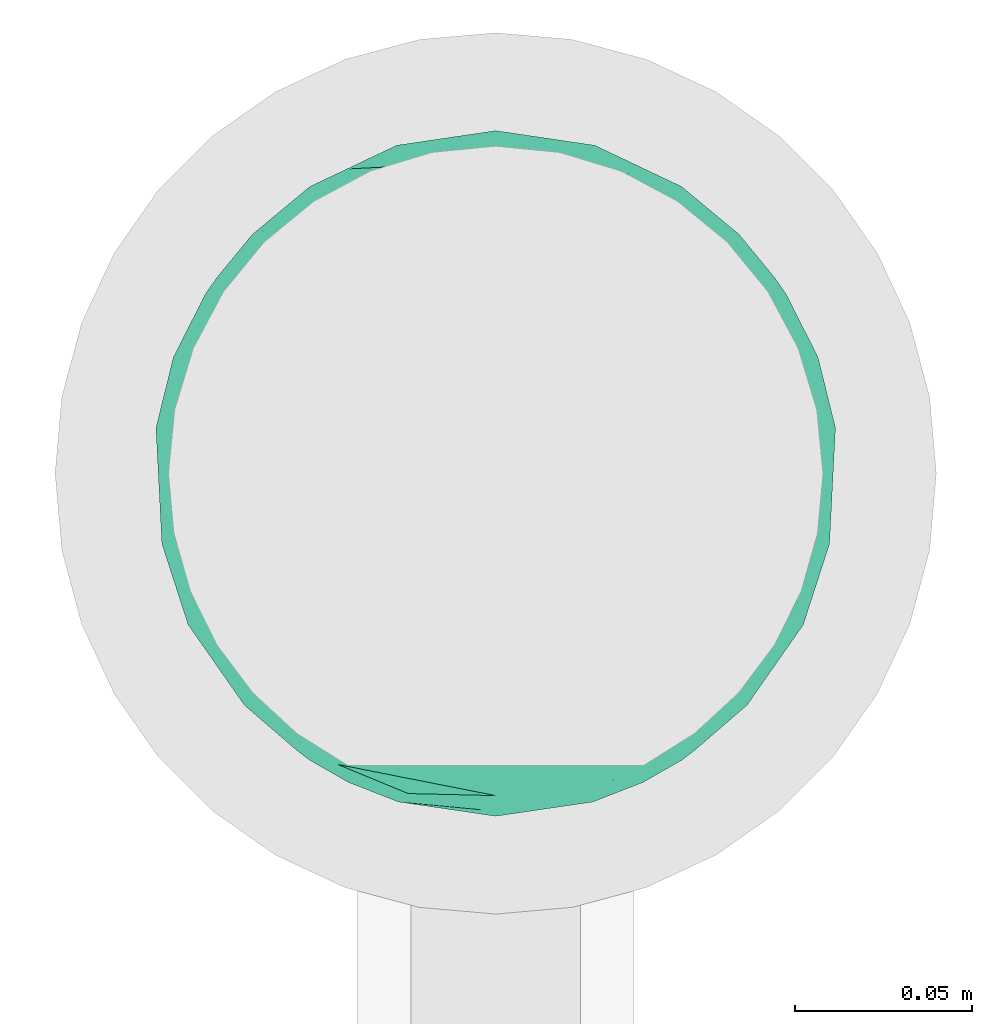
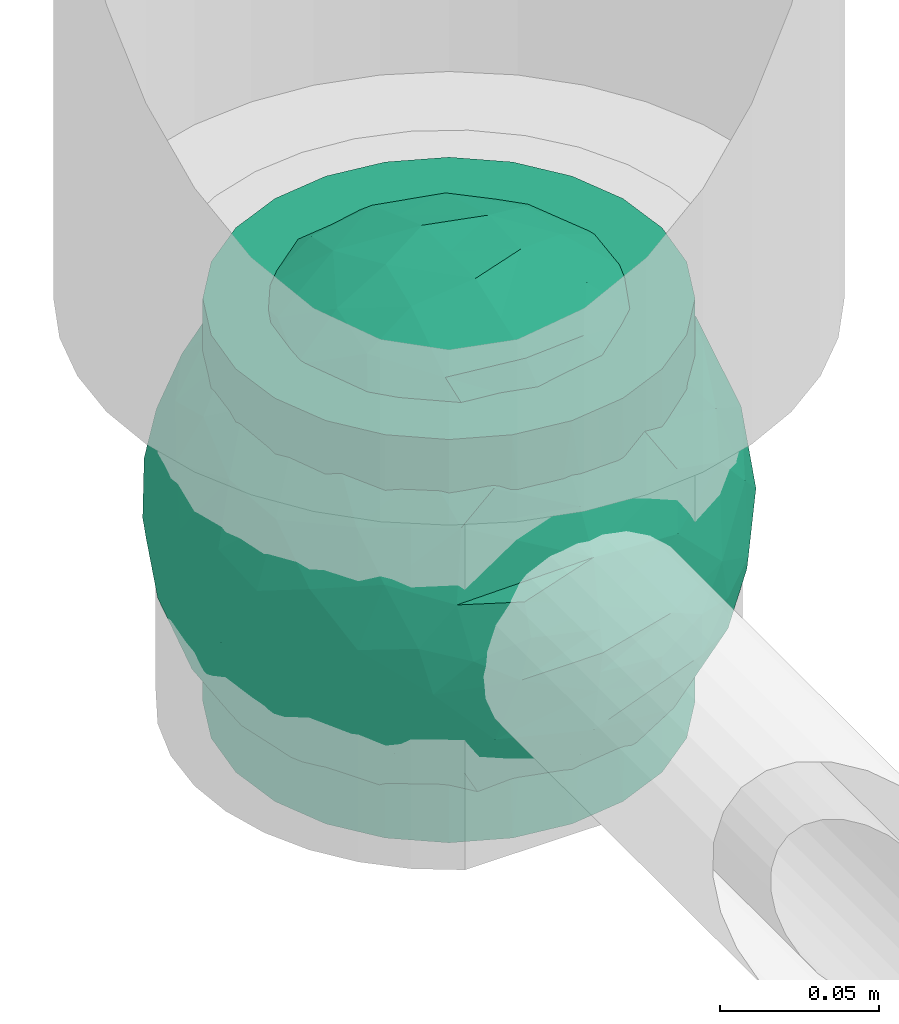
# One storey, part 33 of 39: 1 flow fitting.
"""IFC2X3 building model written with IfcOpenShell, lengths in millimetres."""

from ifc_helpers import new_model, entity, si_unit, converted_unit, derived_unit, direction, frame, origin, place, context, subcontext, project, spatial, faceted_brep, source, transform, mapped, material, material_list, type_object, type_shapes, element, save


model = new_model("IFC2X3")

# Units and contexts
model_context = context("Model", 3, precision=0.01, world=origin(), true_north=direction((6.12303176911189e-17, 1.0)))
body_context = subcontext(model_context, "Body", "Model", "MODEL_VIEW")
ifc_project = project(units=[si_unit("LENGTHUNIT", "METRE", prefix="MILLI"), si_unit("AREAUNIT", "SQUARE_METRE"), si_unit("VOLUMEUNIT", "CUBIC_METRE"), converted_unit("PLANEANGLEUNIT", "DEGREE", entity("IfcRatioMeasure", 0.0174532925199433), si_unit("PLANEANGLEUNIT", "RADIAN"), dimensions=[0, 0, 0, 0, 0, 0, 0]), si_unit("MASSUNIT", "GRAM", prefix="KILO"), derived_unit("MASSDENSITYUNIT", [(si_unit("MASSUNIT", "GRAM", prefix="KILO"), 1), (si_unit("LENGTHUNIT", "METRE"), -3)]), derived_unit("MOMENTOFINERTIAUNIT", [(si_unit("LENGTHUNIT", "METRE"), 4)]), si_unit("TIMEUNIT", "SECOND"), si_unit("FREQUENCYUNIT", "HERTZ"), si_unit("THERMODYNAMICTEMPERATUREUNIT", "DEGREE_CELSIUS"), derived_unit("THERMALTRANSMITTANCEUNIT", [(si_unit("MASSUNIT", "GRAM", prefix="KILO"), 1), (si_unit("THERMODYNAMICTEMPERATUREUNIT", "KELVIN"), -1), (si_unit("TIMEUNIT", "SECOND"), -3)]), derived_unit("VOLUMETRICFLOWRATEUNIT", [(si_unit("LENGTHUNIT", "METRE"), 3), (si_unit("TIMEUNIT", "SECOND"), -1)]), derived_unit("MASSFLOWRATEUNIT", [(si_unit("MASSUNIT", "GRAM", prefix="KILO"), 1), (si_unit("TIMEUNIT", "SECOND"), -1)]), derived_unit("ROTATIONALFREQUENCYUNIT", [(si_unit("TIMEUNIT", "SECOND"), -1)]), si_unit("ELECTRICCURRENTUNIT", "AMPERE"), si_unit("ELECTRICVOLTAGEUNIT", "VOLT"), si_unit("POWERUNIT", "WATT"), si_unit("FORCEUNIT", "NEWTON", prefix="KILO"), si_unit("ILLUMINANCEUNIT", "LUX"), si_unit("LUMINOUSFLUXUNIT", "LUMEN"), si_unit("LUMINOUSINTENSITYUNIT", "CANDELA"), derived_unit("USERDEFINED", [(si_unit("MASSUNIT", "GRAM", prefix="KILO"), -1), (si_unit("LENGTHUNIT", "METRE"), -2), (si_unit("TIMEUNIT", "SECOND"), 3), (si_unit("LUMINOUSFLUXUNIT", "LUMEN"), 1)]), derived_unit("LINEARVELOCITYUNIT", [(si_unit("LENGTHUNIT", "METRE"), 1), (si_unit("TIMEUNIT", "SECOND"), -1)]), si_unit("PRESSUREUNIT", "PASCAL"), derived_unit("USERDEFINED", [(si_unit("LENGTHUNIT", "METRE"), -2), (si_unit("MASSUNIT", "GRAM", prefix="KILO"), 1), (si_unit("TIMEUNIT", "SECOND"), -2)]), derived_unit("LINEARFORCEUNIT", [(si_unit("MASSUNIT", "GRAM", prefix="KILO"), 1), (si_unit("LENGTHUNIT", "METRE"), 1), (si_unit("TIMEUNIT", "SECOND"), -2), (si_unit("LENGTHUNIT", "METRE"), -1)]), derived_unit("PLANARFORCEUNIT", [(si_unit("MASSUNIT", "GRAM", prefix="KILO"), 1), (si_unit("LENGTHUNIT", "METRE"), 1), (si_unit("TIMEUNIT", "SECOND"), -2), (si_unit("LENGTHUNIT", "METRE"), -2)])], contexts=[model_context])

# Site, building, storey
site_placement = place(None, origin())
site = spatial("IfcSite", under=ifc_project, at=site_placement, CompositionType="ELEMENT")
building_placement = place(site_placement, origin())
building = spatial("IfcBuilding", under=site, at=building_placement, CompositionType="ELEMENT")
storey_placement = place(building_placement, frame((0.0, 0.0, 24000.0)))
storey = spatial("IfcBuildingStorey", under=building, at=storey_placement, Name="07", CompositionType="ELEMENT", Elevation=24000.0)

# Flow fitting
ifc_material_1 = material()
ifc_material_2 = material(Name="ADSK_")
ifc_material_list = material_list([ifc_material_1, ifc_material_2])
pipe_fitting_type = type_object("IfcPipeFittingType", Name="ADSK_1", PredefinedType="NOTDEFINED", material=ifc_material_list)
shared_shape = source(origin(), body_context, "Body", "Brep", [
    faceted_brep([(-77.5, 38.75, -67.12), (-77.5, 20.06, -74.86), (-77.5, 0.0, -77.5), (-77.5, -20.06, -74.86), (-77.5, -38.75, -67.12), (-77.5, -54.8, -54.8), (-77.5, -67.12, -38.75), (-77.5, -74.86, -20.06), (-77.5, -76.18, -10.03), (-77.5, -77.5, 0.0), (-77.5, -76.18, 10.03), (-77.5, -74.86, 20.06), (-77.5, -67.12, 38.75), (-77.5, -54.8, 54.8), (-77.5, -38.75, 67.12), (-77.5, -20.06, 74.86), (-77.5, 0.0, 77.5), (-77.5, 20.06, 74.86), (-77.5, 38.75, 67.12), (-77.5, 54.8, 54.8), (-77.5, 67.12, 38.75), (-77.5, 74.86, 20.06), (-77.5, 77.5, 0.0), (-77.5, 74.86, -20.06), (-77.5, 67.12, -38.75), (-77.5, 54.8, -54.8), (77.5, 0.0, -77.5), (77.5, 20.06, -74.86), (77.5, 38.75, -67.12), (77.5, 54.8, -54.8), (77.5, 67.12, -38.75), (77.5, 74.86, -20.06), (77.5, 77.5, 0.0), (77.5, 74.86, 20.06), (77.5, 67.12, 38.75), (77.5, 54.8, 54.8), (77.5, 38.75, 67.12), (77.5, 20.06, 74.86), (77.5, 0.0, 77.5), (77.5, -20.06, 74.86), (77.5, -38.75, 67.12), (77.5, -54.8, 54.8), (77.5, -67.12, 38.75), (77.5, -74.86, 20.06), (77.5, -76.18, 10.03), (77.5, -77.5, 0.0), (77.5, -76.18, -10.03), (77.5, -74.86, -20.06), (77.5, -67.12, -38.75), (77.5, -54.8, -54.8), (77.5, -38.75, -67.12), (77.5, -20.06, -74.86), (21.13, -77.11, 7.72), (21.82, -77.31, 3.86), (22.5, -77.5, 0.0), (17.23, -76.14, 14.47), (3.92, -74.27, 22.16), (7.6, -74.64, 20.81), (11.27, -75.01, 19.47), (-17.23, -76.14, 14.47), (-21.13, -77.11, 7.72), (-22.5, -77.5, 0.0), (-21.82, -77.31, 3.86), (-11.28, -75.01, 19.47), (-7.6, -74.64, 20.81), (-3.93, -74.27, 22.15), (0.0, -74.27, 22.15), (3.92, -74.27, -22.16), (11.27, -75.01, -19.47), (7.6, -74.64, -20.81), (21.82, -77.31, -3.86), (21.13, -77.11, -7.72), (17.23, -76.14, -14.47), (-21.13, -77.11, -7.72), (0.0, -74.27, -22.15), (-3.93, -74.27, -22.15), (-7.6, -74.64, -20.81), (-11.28, -75.01, -19.47), (-17.23, -76.14, -14.47), (-21.82, -77.31, -3.86), (0.0, -82.5, -22.5), (5.82, -82.5, -21.73), (11.25, -82.5, -19.49), (15.91, -82.5, -15.91), (19.49, -82.5, -11.25), (21.73, -82.5, -5.82), (22.5, -82.5, 0.0), (21.73, -82.5, 5.82), (19.49, -82.5, 11.25), (15.91, -82.5, 15.91), (11.25, -82.5, 19.49), (5.82, -82.5, 21.73), (0.0, -82.5, 22.5), (-5.82, -82.5, 21.73), (-11.25, -82.5, 19.49), (-15.91, -82.5, 15.91), (-19.49, -82.5, 11.25), (-21.73, -82.5, 5.82), (-22.5, -82.5, 0.0), (-21.73, -82.5, -5.82), (-19.49, -82.5, -11.25), (-15.91, -82.5, -15.91), (-11.25, -82.5, -19.49), (-5.82, -82.5, -21.73)], [[[0, 1, 2, 3, 4, 5, 6, 7, 8, 9, 10, 11, 12, 13, 14, 15, 16, 17, 18, 19, 20, 21, 22, 23, 24, 25]], [[26, 27, 28, 29, 30, 31, 32, 33, 34, 35, 36, 37, 38, 39, 40, 41, 42, 43, 44, 45, 46, 47, 48, 49, 50, 51]], [[45, 52, 53, 54]], [[55, 52, 44]], [[44, 43, 55]], [[56, 42, 12]], [[43, 56, 57, 58]], [[43, 58, 55]], [[56, 43, 42]], [[42, 41, 13, 12]], [[59, 10, 60]], [[9, 60, 10]], [[9, 61, 62, 60]], [[59, 11, 10]], [[11, 63, 64, 65]], [[65, 12, 11]], [[12, 65, 66, 56]], [[63, 11, 59]], [[52, 45, 44]], [[41, 40, 14, 13]], [[16, 15, 39, 38]], [[15, 14, 40, 39]], [[17, 16, 38, 37]], [[34, 33, 21, 20]], [[19, 18, 36, 35]], [[20, 19, 35, 34]], [[37, 36, 18, 17]], [[22, 21, 33, 32]], [[24, 23, 31, 30]], [[23, 22, 32, 31]], [[25, 24, 30, 29]], [[26, 51, 3, 2]], [[1, 0, 28, 27]], [[2, 1, 27, 26]], [[29, 28, 0, 25]], [[4, 3, 51, 50]], [[50, 49, 5, 4]], [[48, 47, 67]], [[6, 48, 67]], [[48, 6, 5, 49]], [[47, 68, 69, 67]], [[45, 54, 70, 71]], [[68, 47, 72]], [[47, 46, 72]], [[73, 9, 8]], [[46, 45, 71]], [[6, 67, 74, 75]], [[7, 6, 75]], [[7, 75, 76, 77]], [[8, 78, 73]], [[72, 46, 71]], [[9, 73, 79, 61]], [[7, 78, 8]], [[78, 7, 77]], [[80, 81, 82, 83, 84, 85, 86, 87, 88, 89, 90, 91, 92, 93, 94, 95, 96, 97, 98, 99, 100, 101, 102, 103]], [[97, 62, 98]], [[59, 96, 95]], [[97, 96, 60]], [[95, 94, 63]], [[97, 60, 62]], [[62, 61, 98]], [[60, 96, 59]], [[64, 63, 94]], [[93, 65, 64]], [[63, 59, 95]], [[92, 56, 66, 65]], [[90, 57, 91]], [[53, 52, 87]], [[56, 92, 91]], [[57, 90, 58]], [[55, 89, 88]], [[90, 89, 58]], [[52, 88, 87]], [[89, 55, 58]], [[56, 91, 57]], [[53, 86, 54]], [[86, 53, 87]], [[52, 55, 88]], [[64, 94, 93]], [[92, 65, 93]], [[85, 70, 86]], [[72, 84, 83]], [[85, 84, 71]], [[83, 82, 68]], [[85, 71, 70]], [[70, 54, 86]], [[71, 84, 72]], [[69, 68, 82]], [[81, 67, 69]], [[68, 72, 83]], [[80, 75, 74, 67]], [[102, 76, 103]], [[79, 73, 99]], [[75, 80, 103]], [[76, 102, 77]], [[100, 78, 101]], [[101, 77, 102]], [[99, 73, 100]], [[101, 78, 77]], [[75, 103, 76]], [[79, 98, 61]], [[98, 79, 99]], [[73, 78, 100]], [[69, 82, 81]], [[80, 67, 81]]]),
    faceted_brep([(74.09, -36.62, -50.54), (86.5, -25.35, -35.5), (82.61, -45.18, -22.81), (-16.75, -33.7, -89.27), (0.0, -42.78, -86.92), (-23.87, -49.97, -79.49), (73.94, -14.61, -60.86), (53.84, -28.63, -75.28), (-16.57, 93.95, 0.0), (-18.09, 86.11, -40.53), (-32.84, 86.73, -28.0), (-44.04, -10.15, -85.69), (-19.2, 4.88, -94.83), (-22.92, -15.62, -92.82), (89.65, 32.63, 0.0), (82.61, 44.34, -24.37), (83.9, 48.44, 0.0), (47.7, -82.62, 0.0), (60.26, -69.94, -29.38), (62.27, -74.21, 0.0), (95.4, 0.0, 0.0), (95.4, -16.82, 0.0), (94.13, -8.44, -21.26), (93.14, 13.95, -22.71), (95.4, 16.82, 0.0), (76.54, 8.21, -58.81), (74.09, 36.62, -50.54), (84.96, 22.7, -40.64), (28.25, -36.42, -85.21), (19.67, -61.78, -71.98), (-67.45, 51.53, -46.69), (-45.73, 54.97, -65.36), (-59.68, 42.12, -63.64), (47.7, 82.62, 0.0), (62.27, 74.21, 0.0), (59.48, 63.11, -43.18), (-48.12, -74.69, -38.62), (-33.13, -91.03, 0.0), (-47.7, -82.62, 0.0), (72.35, 57.3, -29.46), (60.01, 43.15, -62.62), (62.52, -52.48, -52.18), (45.73, -54.97, -65.36), (-62.27, -74.21, 0.0), (-73.08, -61.32, 0.0), (-72.41, -59.62, -24.21), (7.26, -81.07, -52.53), (35.35, -68.17, -59.06), (27.87, -86.63, -33.22), (-74.09, -36.62, -50.54), (-84.35, -21.79, -42.37), (-76.59, -6.33, -58.98), (61.55, 0.0, -74.81), (-61.55, 0.0, -74.81), (-79.37, 15.54, -53.33), (-95.4, -16.82, 0.0), (-92.58, -16.52, -23.25), (-89.65, -32.63, 0.0), (63.81, 22.67, -69.28), (-18.69, 68.07, -66.35), (-42.94, 76.94, -40.26), (-74.09, 36.62, -50.54), (-43.64, 36.19, -78.55), (-65.1, 21.71, -68.38), (44.46, 15.06, -84.74), (-65.04, -21.76, -68.42), (-94.63, 4.93, -20.13), (-87.93, 0.0, -40.67), (-89.65, 32.63, 0.0), (-89.27, 26.35, -26.85), (27.96, 84.78, -37.61), (7.26, 81.07, -52.53), (1.19, 92.73, -28.0), (3.41, -92.84, -27.46), (-8.28, -95.41, 0.0), (-11.9, -93.14, -23.83), (73.08, 61.32, 0.0), (87.93, 0.0, -40.67), (73.08, -61.32, 0.0), (83.9, -48.44, 0.0), (-73.08, 61.32, 0.0), (-82.24, 45.34, -23.77), (-83.9, 48.44, 0.0), (-63.57, -59.47, -42.5), (-45.73, -54.97, -65.36), (-82.58, -43.28, -26.32), (29.11, 48.1, -78.89), (45.73, 54.97, -65.36), (44.58, 36.0, -78.11), (-61.2, 65.56, -36.61), (-6.93, -65.5, -71.03), (30.56, -5.14, -91.79), (9.54, -19.86, -94.34), (0.0, 12.89, -96.01), (47.81, -10.83, -83.56), (89.65, -32.63, 0.0), (44.95, 76.64, -38.61), (33.13, 91.03, 0.0), (28.53, 69.09, -61.62), (-51.45, 14.65, -80.76), (22.17, 26.71, -90.44), (33.13, -91.03, 0.0), (44.95, -76.64, -38.61), (72.35, -57.3, -29.46), (16.57, -93.95, 0.0), (-15.25, 22.47, -92.99), (2.72, 32.92, -91.07), (8.92, 50.75, -82.03), (9.42, 67.57, -68.78), (16.57, 93.95, 0.0), (-5.45, -87.35, -41.54), (8.28, -95.41, 0.0), (0.0, -96.88, 0.0), (-24.34, -90.45, -24.71), (-25.14, -82.23, -44.62), (-16.57, -93.95, 0.0), (-9.92, -78.26, -56.23), (-30.26, -67.58, -62.46), (-40.87, -32.58, -81.57), (-34.66, 17.97, -88.66), (-59.69, -42.16, -63.59), (-16.8, 39.61, -86.8), (-28.19, 53.95, -75.36), (-10.32, 55.25, -78.9), (-57.91, -73.21, -25.92), (-83.9, -48.44, 0.0), (-95.4, 0.0, 0.0), (-95.4, 16.82, 0.0), (-72.43, 58.81, -26.08), (-62.27, 74.21, 0.0), (-47.7, 82.62, 0.0), (-33.13, 91.03, 0.0), (0.0, 96.87, 0.0), (-74.09, -36.62, 50.54), (-86.5, -25.35, 35.5), (-82.61, -45.18, 22.81), (16.75, -33.7, 89.27), (0.0, -42.78, 86.92), (23.87, -49.97, 79.49), (-73.94, -14.61, 60.86), (-53.84, -28.63, 75.28), (18.09, 86.11, 40.53), (32.84, 86.73, 28.0), (44.04, -10.15, 85.69), (19.2, 4.88, 94.83), (22.92, -15.62, 92.82), (-82.61, 44.34, 24.37), (-60.26, -69.94, 29.38), (-94.13, -8.44, 21.26), (-93.14, 13.95, 22.71), (-76.54, 8.21, 58.81), (-74.09, 36.62, 50.54), (-84.96, 22.7, 40.64), (-28.25, -36.42, 85.21), (-19.67, -61.78, 71.98), (67.45, 51.53, 46.69), (45.73, 54.97, 65.36), (59.68, 42.12, 63.64), (-28.53, 69.09, 61.62), (-45.73, 54.97, 65.36), (-29.11, 48.1, 78.89), (48.12, -74.69, 38.62), (-59.48, 63.11, 43.18), (-72.35, 57.3, 29.46), (-60.01, 43.15, 62.62), (-35.35, -68.17, 59.06), (-7.26, -81.07, 52.53), (72.41, -59.62, 24.21), (-3.41, -92.84, 27.46), (74.09, -36.62, 50.54), (84.35, -21.79, 42.37), (76.59, -6.33, 58.98), (-61.55, 0.0, 74.81), (61.55, 0.0, 74.81), (79.37, 15.54, 53.33), (92.58, -16.52, 23.25), (-63.81, 22.67, 69.28), (18.69, 68.07, 66.35), (42.94, 76.94, 40.26), (74.09, 36.62, 50.54), (43.64, 36.19, 78.55), (65.1, 21.71, 68.38), (-44.46, 15.06, 84.74), (65.04, -21.76, 68.42), (94.63, 4.93, 20.13), (87.93, 0.0, 40.67), (89.27, 26.35, 26.85), (-27.96, 84.78, 37.61), (-7.26, 81.07, 52.53), (-1.19, 92.73, 28.0), (11.9, -93.14, 23.83), (-87.93, 0.0, 40.67), (82.24, 45.34, 23.77), (63.57, -59.47, 42.5), (45.73, -54.97, 65.36), (82.58, -43.28, 26.32), (-44.58, 36.0, 78.11), (61.2, 65.56, 36.61), (25.14, -82.23, 44.62), (5.45, -87.35, 41.54), (24.34, -90.45, 24.71), (6.93, -65.5, 71.03), (-30.56, -5.14, 91.79), (-9.54, -19.86, 94.34), (0.0, 12.89, 96.01), (-47.81, -10.83, 83.56), (-44.95, 76.64, 38.61), (51.45, 14.65, 80.76), (-62.52, -52.48, 52.18), (-45.73, -54.97, 65.36), (-22.17, 26.71, 90.44), (-44.95, -76.64, 38.61), (-72.35, -57.3, 29.46), (-27.87, -86.63, 33.22), (15.25, 22.47, 92.99), (-2.72, 32.92, 91.07), (-8.92, 50.75, 82.03), (-9.42, 67.57, 68.78), (9.92, -78.26, 56.23), (30.26, -67.58, 62.46), (40.87, -32.58, 81.57), (34.66, 17.97, 88.66), (59.69, -42.16, 63.59), (16.8, 39.61, 86.8), (28.19, 53.95, 75.36), (10.32, 55.25, 78.9), (57.91, -73.21, 25.92), (72.43, 58.81, 26.08)], [[[0, 1, 2]], [[3, 4, 5]], [[6, 0, 7]], [[8, 9, 10]], [[11, 12, 13]], [[14, 15, 16]], [[17, 18, 19]], [[20, 21, 22]], [[23, 24, 20]], [[25, 26, 27]], [[4, 28, 29]], [[30, 31, 32]], [[33, 34, 35]], [[36, 37, 38]], [[35, 39, 40]], [[41, 18, 42]], [[43, 44, 45]], [[46, 47, 48]], [[49, 50, 51]], [[52, 25, 6]], [[53, 51, 54]], [[55, 56, 57]], [[26, 25, 58]], [[59, 31, 60]], [[32, 61, 30]], [[62, 63, 32]], [[52, 64, 58]], [[51, 65, 49]], [[56, 66, 67]], [[66, 68, 69]], [[70, 71, 72]], [[73, 74, 75]], [[6, 7, 52]], [[20, 22, 23]], [[76, 39, 34]], [[15, 26, 39]], [[1, 77, 22]], [[78, 2, 79]], [[61, 54, 69]], [[80, 81, 82]], [[36, 83, 84]], [[85, 56, 50]], [[86, 87, 88]], [[60, 31, 89]], [[48, 73, 46]], [[4, 29, 90]], [[91, 92, 93]], [[7, 94, 52]], [[77, 23, 22]], [[95, 79, 2]], [[0, 6, 1]], [[1, 22, 95]], [[1, 95, 2]], [[27, 23, 77]], [[15, 14, 23]], [[25, 27, 77]], [[15, 76, 16]], [[40, 39, 26]], [[39, 76, 15]], [[96, 97, 33]], [[70, 98, 71]], [[39, 35, 34]], [[87, 86, 98]], [[77, 1, 6]], [[25, 52, 58]], [[62, 99, 63]], [[26, 15, 27]], [[6, 25, 77]], [[0, 41, 7]], [[42, 28, 7]], [[92, 91, 28]], [[94, 28, 91]], [[88, 87, 40]], [[52, 94, 64]], [[40, 26, 58]], [[100, 91, 93]], [[88, 40, 58]], [[22, 21, 95]], [[101, 102, 17]], [[103, 78, 19]], [[41, 0, 103]], [[18, 102, 42]], [[101, 48, 102]], [[101, 104, 48]], [[29, 28, 42]], [[28, 4, 92]], [[102, 47, 42]], [[90, 29, 46]], [[88, 58, 64]], [[40, 87, 35]], [[87, 96, 35]], [[33, 35, 96]], [[100, 64, 91]], [[88, 64, 100]], [[12, 105, 93]], [[98, 96, 87]], [[106, 100, 93]], [[86, 100, 107]], [[100, 86, 88]], [[98, 108, 71]], [[108, 86, 107]], [[109, 70, 72]], [[70, 109, 97]], [[96, 98, 70]], [[97, 96, 70]], [[78, 103, 2]], [[0, 2, 103]], [[41, 103, 18]], [[7, 41, 42]], [[19, 18, 103]], [[102, 18, 17]], [[75, 110, 73]], [[73, 104, 111, 112]], [[113, 114, 110]], [[115, 75, 74]], [[36, 114, 37]], [[90, 5, 4]], [[73, 48, 104]], [[47, 46, 29]], [[46, 116, 90]], [[5, 117, 84]], [[90, 116, 117]], [[118, 13, 3]], [[118, 5, 84]], [[11, 119, 12]], [[65, 120, 49]], [[11, 13, 118]], [[63, 53, 54]], [[121, 122, 123]], [[90, 117, 5]], [[49, 120, 83]], [[117, 36, 84]], [[36, 117, 114]], [[43, 45, 124]], [[38, 124, 36]], [[83, 124, 45]], [[85, 125, 57]], [[125, 85, 44]], [[45, 49, 83]], [[66, 55, 126, 127]], [[57, 56, 85]], [[56, 67, 50]], [[51, 50, 67]], [[85, 50, 49]], [[54, 51, 67]], [[51, 53, 65]], [[69, 54, 67]], [[54, 61, 63]], [[69, 67, 66]], [[128, 129, 89]], [[11, 65, 53]], [[120, 118, 84]], [[32, 63, 61]], [[99, 53, 63]], [[118, 120, 65]], [[83, 120, 84]], [[129, 128, 80]], [[62, 32, 31]], [[60, 130, 131]], [[130, 60, 89]], [[9, 71, 59]], [[10, 60, 131]], [[108, 59, 71]], [[71, 9, 72]], [[62, 121, 119]], [[122, 59, 123]], [[62, 119, 99]], [[62, 31, 122]], [[106, 107, 100]], [[44, 85, 45]], [[49, 45, 85]], [[55, 66, 56]], [[62, 122, 121]], [[89, 129, 130]], [[65, 11, 118]], [[11, 53, 99]], [[80, 128, 81]], [[30, 128, 89]], [[81, 61, 69]], [[61, 81, 128]], [[82, 81, 69]], [[10, 59, 60]], [[72, 8, 132]], [[8, 72, 9]], [[109, 72, 132]], [[3, 92, 4]], [[92, 13, 12]], [[23, 27, 15]], [[14, 24, 23]], [[11, 99, 119]], [[128, 30, 61]], [[31, 30, 89]], [[28, 94, 7]], [[64, 94, 91]], [[48, 47, 102]], [[29, 42, 47]], [[105, 106, 93]], [[123, 106, 121]], [[86, 108, 98]], [[108, 107, 123]], [[73, 112, 74]], [[113, 75, 115]], [[114, 116, 110]], [[115, 37, 113]], [[37, 114, 113]], [[46, 73, 110]], [[117, 116, 114]], [[110, 75, 113]], [[46, 110, 116]], [[118, 3, 5]], [[92, 3, 13]], [[105, 119, 121]], [[92, 12, 93]], [[119, 105, 12]], [[106, 105, 121]], [[43, 124, 38]], [[83, 36, 124]], [[68, 66, 127]], [[68, 82, 69]], [[31, 59, 122]], [[108, 123, 59]], [[106, 123, 107]], [[8, 10, 131]], [[59, 10, 9]], [[133, 134, 135]], [[136, 137, 138]], [[139, 133, 140]], [[109, 141, 142]], [[143, 144, 145]], [[68, 146, 82]], [[38, 147, 43]], [[148, 126, 55]], [[149, 127, 126]], [[150, 151, 152]], [[137, 153, 154]], [[155, 156, 157]], [[158, 159, 160]], [[161, 101, 17]], [[162, 163, 164]], [[154, 165, 166]], [[19, 78, 167]], [[168, 115, 74, 112]], [[169, 170, 171]], [[172, 150, 139]], [[173, 171, 174]], [[21, 175, 95]], [[151, 150, 176]], [[177, 156, 178]], [[157, 179, 155]], [[180, 181, 157]], [[172, 182, 176]], [[171, 183, 169]], [[175, 184, 185]], [[186, 24, 14, 16]], [[187, 188, 189]], [[168, 111, 190]], [[139, 140, 172]], [[126, 148, 149]], [[80, 163, 129]], [[146, 151, 163]], [[134, 191, 148]], [[44, 135, 125]], [[179, 174, 186]], [[76, 192, 16]], [[161, 193, 194]], [[195, 175, 170]], [[160, 159, 196]], [[178, 156, 197]], [[198, 199, 200]], [[137, 154, 201]], [[202, 203, 204]], [[140, 205, 172]], [[134, 133, 139]], [[125, 135, 57]], [[148, 191, 149]], [[134, 148, 57]], [[134, 57, 135]], [[152, 149, 191]], [[146, 68, 149]], [[150, 152, 191]], [[146, 80, 82]], [[164, 163, 151]], [[163, 80, 146]], [[162, 130, 129]], [[130, 206, 131]], [[163, 162, 129]], [[158, 188, 187]], [[191, 134, 139]], [[150, 172, 176]], [[180, 207, 181]], [[151, 146, 152]], [[139, 150, 191]], [[133, 208, 140]], [[209, 153, 140]], [[203, 202, 153]], [[205, 153, 202]], [[196, 159, 164]], [[172, 205, 182]], [[164, 151, 176]], [[210, 202, 204]], [[196, 164, 176]], [[148, 55, 57]], [[38, 37, 211]], [[212, 44, 43]], [[208, 133, 212]], [[147, 211, 209]], [[165, 213, 166]], [[209, 208, 147]], [[154, 153, 209]], [[153, 137, 203]], [[211, 165, 209]], [[201, 154, 166]], [[196, 176, 182]], [[164, 159, 162]], [[159, 206, 162]], [[130, 162, 206]], [[210, 182, 202]], [[196, 182, 210]], [[144, 214, 204]], [[158, 206, 159]], [[215, 210, 204]], [[160, 210, 216]], [[210, 160, 196]], [[158, 217, 188]], [[217, 160, 216]], [[8, 187, 189]], [[187, 8, 131]], [[206, 158, 187]], [[131, 206, 187]], [[44, 212, 135]], [[133, 135, 212]], [[208, 212, 147]], [[140, 208, 209]], [[43, 147, 212]], [[211, 147, 38]], [[199, 168, 190]], [[213, 115, 168]], [[213, 168, 166]], [[104, 190, 111]], [[161, 198, 101]], [[201, 138, 137]], [[37, 115, 213]], [[211, 37, 213]], [[166, 218, 201]], [[138, 219, 194]], [[201, 218, 219]], [[220, 145, 136]], [[220, 138, 194]], [[143, 221, 144]], [[183, 222, 169]], [[143, 145, 220]], [[181, 173, 174]], [[223, 224, 225]], [[201, 219, 138]], [[169, 222, 193]], [[219, 161, 194]], [[161, 219, 198]], [[19, 167, 226]], [[17, 226, 161]], [[193, 226, 167]], [[195, 79, 95]], [[79, 195, 78]], [[167, 169, 193]], [[184, 21, 20, 24]], [[95, 175, 195]], [[175, 185, 170]], [[171, 170, 185]], [[195, 170, 169]], [[174, 171, 185]], [[171, 173, 183]], [[186, 174, 185]], [[174, 179, 181]], [[186, 185, 184]], [[227, 34, 197]], [[143, 183, 173]], [[222, 220, 194]], [[157, 181, 179]], [[207, 173, 181]], [[220, 222, 183]], [[193, 222, 194]], [[34, 227, 76]], [[180, 157, 156]], [[178, 33, 97]], [[33, 178, 197]], [[141, 188, 177]], [[142, 178, 97]], [[217, 177, 188]], [[188, 141, 189]], [[180, 223, 221]], [[224, 177, 225]], [[180, 221, 207]], [[180, 156, 224]], [[215, 216, 210]], [[78, 195, 167]], [[169, 167, 195]], [[21, 184, 175]], [[186, 184, 24]], [[197, 34, 33]], [[183, 143, 220]], [[143, 173, 207]], [[76, 227, 192]], [[155, 227, 197]], [[192, 179, 186]], [[179, 192, 227]], [[16, 192, 186]], [[142, 177, 178]], [[189, 109, 132]], [[109, 189, 141]], [[8, 189, 132]], [[136, 203, 137]], [[203, 145, 144]], [[149, 152, 146]], [[68, 127, 149]], [[143, 207, 221]], [[227, 155, 179]], [[156, 155, 197]], [[153, 205, 140]], [[182, 205, 202]], [[213, 165, 211]], [[154, 209, 165]], [[214, 215, 204]], [[225, 215, 223]], [[160, 217, 158]], [[217, 216, 225]], [[168, 112, 111]], [[200, 190, 104]], [[198, 218, 199]], [[104, 101, 200]], [[101, 198, 200]], [[166, 168, 199]], [[219, 218, 198]], [[199, 190, 200]], [[166, 199, 218]], [[220, 136, 138]], [[203, 136, 145]], [[214, 221, 223]], [[203, 144, 204]], [[221, 214, 144]], [[215, 214, 223]], [[19, 226, 17]], [[193, 161, 226]], [[180, 224, 223]], [[156, 177, 224]], [[217, 225, 177]], [[215, 225, 216]], [[109, 142, 97]], [[177, 142, 141]]]),
])
type_shapes(pipe_fitting_type, [shared_shape])
flow_fitting_placement = place(storey_placement, frame((31080.0, 10950.0, 2660.0), z_axis=(-1.0, 0.0, 0.0), x_axis=(0.0, 0.0, 1.0)))
element("IfcFlowFitting", 1, at=flow_fitting_placement, inside=storey, type_object=pipe_fitting_type, material=ifc_material_list, Name="ADSK_1", ObjectType="ADSK_1", context=body_context, shape_type="MappedRepresentation", body=[
    mapped(shared_shape, transform((0.0, 0.0, 0.0), scale=1.0)),
])

save(model, "model.ifc")
